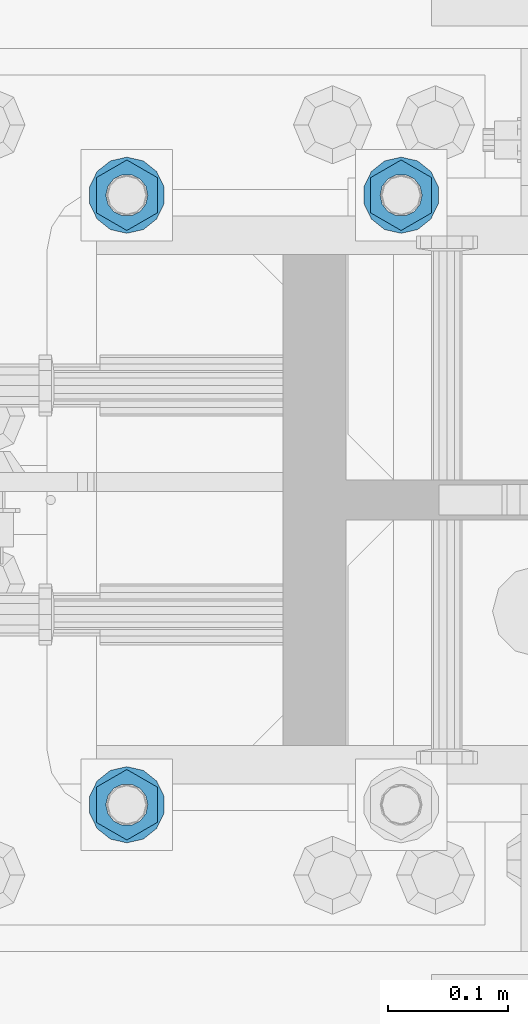
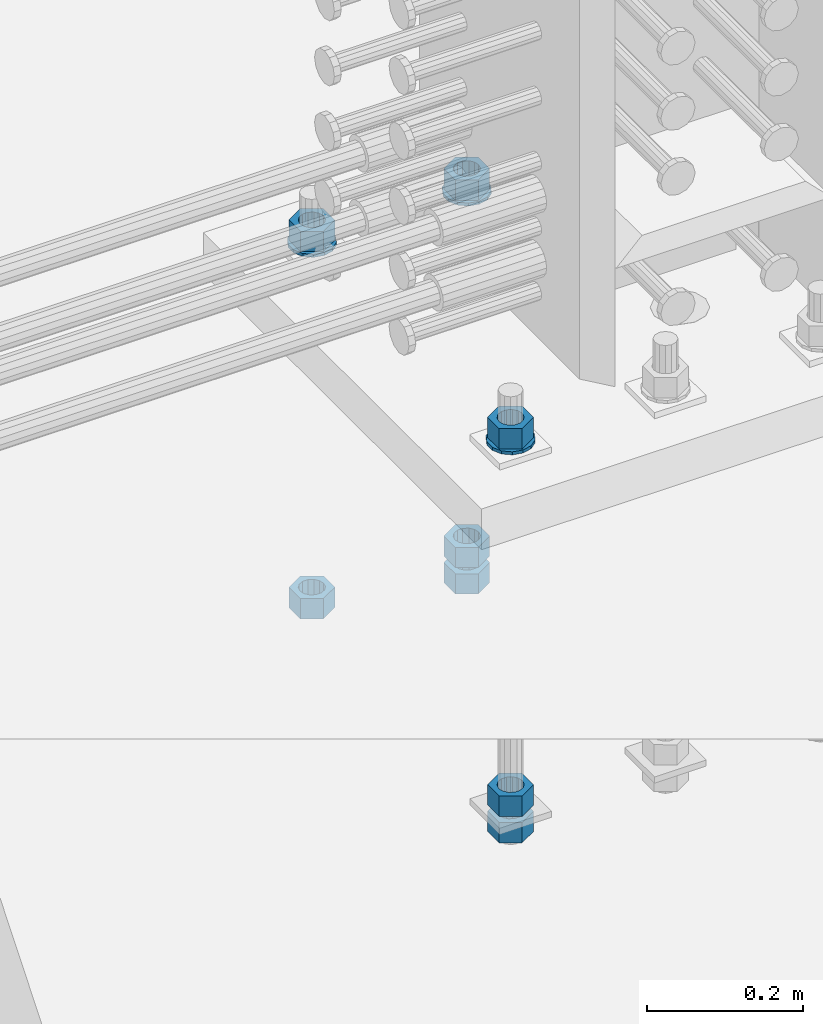
# One storey, part 1001 of 1763: 11 columns, 1 element without a shape of its own.
"""IFC2X3 building model written with IfcOpenShell, lengths in millimetres."""

from ifc_helpers import new_model, si_unit, frame, origin_with_axes, place, context, subcontext, project, spatial, faceted_brep, material, type_object, element, aggregate, save


model = new_model("IFC2X3")

# Units and contexts
model_context = context("Model", 3, precision=1e-05, world=origin_with_axes())
body_context = subcontext(model_context, "Body", "Model", "MODEL_VIEW")
ifc_project = project(units=[si_unit("LENGTHUNIT", "METRE", prefix="MILLI"), si_unit("AREAUNIT", "SQUARE_METRE"), si_unit("VOLUMEUNIT", "CUBIC_METRE"), si_unit("MASSUNIT", "GRAM", prefix="KILO"), si_unit("TIMEUNIT", "SECOND"), si_unit("PLANEANGLEUNIT", "RADIAN"), si_unit("SOLIDANGLEUNIT", "STERADIAN"), si_unit("THERMODYNAMICTEMPERATUREUNIT", "DEGREE_CELSIUS"), si_unit("LUMINOUSINTENSITYUNIT", "LUMEN")], contexts=[model_context])

# Site, building, storey
site_placement = place(None, origin_with_axes())
site = spatial("IfcSite", under=ifc_project, at=site_placement, CompositionType="ELEMENT")
building_placement = place(site_placement, origin_with_axes())
building = spatial("IfcBuilding", under=site, at=building_placement, Name="Undefined", CompositionType="ELEMENT")
storey_placement = place(building_placement, origin_with_axes())
storey = spatial("IfcBuildingStorey", under=building, at=storey_placement, Name="Undefined", CompositionType="ELEMENT", Elevation=0.0)

# Assembly, columns
assembly_placement = place(storey_placement, origin_with_axes())
assembly = element("IfcElementAssembly", 1, at=assembly_placement, inside=storey, Name="TEMPLATE", AssemblyPlace="NOTDEFINED", PredefinedType="RIGID_FRAME")
ifc_material_1 = material(Name="STEEL/A563")
column_type_1 = type_object("IfcColumnType", Name="1-1/4_HEAVY_HEX_NUT", PredefinedType="NOTDEFINED")
column_1_placement = place(assembly_placement, frame((-49516.7372736986, 711.200000000003, 3957.6375), z_axis=(-1.0, 0.0, 0.0), x_axis=(0.0, 0.0, -1.0)))
column_1 = element("IfcColumn", 2, at=column_1_placement, type_object=column_type_1, material=ifc_material_1, Name="NUT", ObjectType="1-1/4_HEAVY_HEX_NUT", context=body_context, shape_type="Brep", body=[
    faceted_brep([(0.0, -29.3700008392334, 0.0), (0.0, -14.6800003051758, -25.4300003051758), (31.75, -14.6800003051758, -25.4300003051758), (31.75, -29.3700008392334, 0.0), (0.0, 14.6800003051758, -25.4300003051758), (31.75, 14.6800003051758, -25.4300003051758), (0.0, 29.3700008392334, 0.0), (31.75, 29.3700008392334, 0.0), (0.0, 14.6800003051758, 25.4300003051758), (31.75, 14.6800003051758, 25.4300003051758), (0.0, -14.6800003051758, 25.4300003051758), (31.75, -14.6800003051758, 25.4300003051758), (0.0, 0.0, 17.4599990844727), (0.0, 7.57560968776022, 15.730915608714), (31.75, 7.57560968775942, 15.7309156087145), (31.75, 0.0, 17.4599990844727), (0.0, 13.6507769681037, 10.8861313696252), (31.75, 13.6507769681048, 10.8861313696314), (0.0, 17.0222404541215, 3.88521530314756), (31.75, 17.02224045412, 3.88521530315316), (0.0, 17.0222404541215, -3.88521530314756), (31.75, 17.02224045412, -3.88521530315332), (0.0, 13.6507769681037, -10.8861313696252), (31.75, 13.6507769681048, -10.8861313696316), (0.0, 7.57560968776022, -15.730915608714), (31.75, 7.57560968775942, -15.7309156087146), (0.0, 0.0, -17.4599990844727), (31.75, 0.0, -17.4599990844727), (0.0, -7.57560968776022, -15.730915608714), (31.75, -7.57560968775942, -15.7309156087145), (0.0, -13.6507769681037, -10.8861313696252), (31.75, -13.6507769681048, -10.8861313696314), (0.0, -17.0222404541215, -3.88521530314756), (31.75, -17.02224045412, -3.88521530315316), (0.0, -17.0222404541215, 3.88521530314756), (31.75, -17.02224045412, 3.88521530315332), (0.0, -13.6507769681037, 10.8861313696252), (31.75, -13.6507769681048, 10.8861313696316), (0.0, -7.57560968776022, 15.730915608714), (31.75, -7.57560968775942, 15.7309156087146)], [[[0, 1, 2, 3]], [[1, 4, 5, 2]], [[4, 6, 7, 5]], [[6, 8, 9, 7]], [[8, 10, 11, 9]], [[10, 0, 3, 11]], [[12, 13, 14, 15]], [[13, 16, 17, 14]], [[16, 18, 19, 17]], [[18, 20, 21, 19]], [[20, 22, 23, 21]], [[22, 24, 25, 23]], [[24, 26, 27, 25]], [[26, 28, 29, 27]], [[28, 30, 31, 29]], [[30, 32, 33, 31]], [[32, 34, 35, 33]], [[34, 36, 37, 35]], [[36, 38, 39, 37]], [[38, 12, 15, 39]], [[5, 7, 9, 11, 3, 2], [17, 19, 21, 23, 25, 27, 29, 31, 33, 35, 37, 39, 15, 14]], [[10, 8, 6, 4, 1, 0], [38, 36, 34, 32, 30, 28, 26, 24, 22, 20, 18, 16, 13, 12]]]),
])
column_2_placement = place(assembly_placement, frame((-49516.7372736986, 711.200000000003, 3384.55), z_axis=(-1.0, 0.0, 0.0), x_axis=(0.0, 0.0, -1.0)))
column_2 = element("IfcColumn", 3, at=column_2_placement, type_object=column_type_1, material=ifc_material_1, Name="NUT", ObjectType="1-1/4_HEAVY_HEX_NUT", context=body_context, shape_type="Brep", body=[
    faceted_brep([(0.0, -29.3700008392334, 0.0), (0.0, -14.6800003051758, -25.4300003051758), (31.75, -14.6800003051758, -25.4300003051758), (31.75, -29.3700008392334, 0.0), (0.0, 14.6800003051758, -25.4300003051758), (31.75, 14.6800003051758, -25.4300003051758), (0.0, 29.3700008392334, 0.0), (31.75, 29.3700008392334, 0.0), (0.0, 14.6800003051758, 25.4300003051758), (31.75, 14.6800003051758, 25.4300003051758), (0.0, -14.6800003051758, 25.4300003051758), (31.75, -14.6800003051758, 25.4300003051758), (0.0, 0.0, 17.4599990844727), (0.0, 7.57560968776022, 15.730915608714), (31.75, 7.57560968775942, 15.7309156087145), (31.75, 0.0, 17.4599990844727), (0.0, 13.6507769681037, 10.8861313696252), (31.75, 13.6507769681048, 10.8861313696314), (0.0, 17.0222404541215, 3.88521530314756), (31.75, 17.02224045412, 3.88521530315316), (0.0, 17.0222404541215, -3.88521530314756), (31.75, 17.02224045412, -3.88521530315332), (0.0, 13.6507769681037, -10.8861313696252), (31.75, 13.6507769681048, -10.8861313696316), (0.0, 7.57560968776022, -15.730915608714), (31.75, 7.57560968775942, -15.7309156087146), (0.0, 0.0, -17.4599990844727), (31.75, 0.0, -17.4599990844727), (0.0, -7.57560968776022, -15.730915608714), (31.75, -7.57560968775942, -15.7309156087145), (0.0, -13.6507769681037, -10.8861313696252), (31.75, -13.6507769681048, -10.8861313696314), (0.0, -17.0222404541215, -3.88521530314756), (31.75, -17.02224045412, -3.88521530315316), (0.0, -17.0222404541215, 3.88521530314756), (31.75, -17.02224045412, 3.88521530315332), (0.0, -13.6507769681037, 10.8861313696252), (31.75, -13.6507769681048, 10.8861313696316), (0.0, -7.57560968776022, 15.730915608714), (31.75, -7.57560968775942, 15.7309156087146)], [[[0, 1, 2, 3]], [[1, 4, 5, 2]], [[4, 6, 7, 5]], [[6, 8, 9, 7]], [[8, 10, 11, 9]], [[10, 0, 3, 11]], [[12, 13, 14, 15]], [[13, 16, 17, 14]], [[16, 18, 19, 17]], [[18, 20, 21, 19]], [[20, 22, 23, 21]], [[22, 24, 25, 23]], [[24, 26, 27, 25]], [[26, 28, 29, 27]], [[28, 30, 31, 29]], [[30, 32, 33, 31]], [[32, 34, 35, 33]], [[34, 36, 37, 35]], [[36, 38, 39, 37]], [[38, 12, 15, 39]], [[5, 7, 9, 11, 3, 2], [17, 19, 21, 23, 25, 27, 29, 31, 33, 35, 37, 39, 15, 14]], [[10, 8, 6, 4, 1, 0], [38, 36, 34, 32, 30, 28, 26, 24, 22, 20, 18, 16, 13, 12]]]),
])
column_3_placement = place(assembly_placement, frame((-49516.7372736986, 711.200000000003, 3343.275), z_axis=(-1.0, 0.0, 0.0), x_axis=(0.0, 0.0, -1.0)))
column_3 = element("IfcColumn", 4, at=column_3_placement, type_object=column_type_1, material=ifc_material_1, Name="NUT", ObjectType="1-1/4_HEAVY_HEX_NUT", context=body_context, shape_type="Brep", body=[
    faceted_brep([(0.0, -29.3700008392334, 0.0), (0.0, -14.6800003051758, -25.4300003051758), (31.75, -14.6800003051758, -25.4300003051758), (31.75, -29.3700008392334, 0.0), (0.0, 14.6800003051758, -25.4300003051758), (31.75, 14.6800003051758, -25.4300003051758), (0.0, 29.3700008392334, 0.0), (31.75, 29.3700008392334, 0.0), (0.0, 14.6800003051758, 25.4300003051758), (31.75, 14.6800003051758, 25.4300003051758), (0.0, -14.6800003051758, 25.4300003051758), (31.75, -14.6800003051758, 25.4300003051758), (0.0, 0.0, 17.4599990844727), (0.0, 7.57560968776022, 15.730915608714), (31.75, 7.57560968775942, 15.7309156087145), (31.75, 0.0, 17.4599990844727), (0.0, 13.6507769681037, 10.8861313696252), (31.75, 13.6507769681048, 10.8861313696314), (0.0, 17.0222404541215, 3.88521530314756), (31.75, 17.02224045412, 3.88521530315316), (0.0, 17.0222404541215, -3.88521530314756), (31.75, 17.02224045412, -3.88521530315332), (0.0, 13.6507769681037, -10.8861313696252), (31.75, 13.6507769681048, -10.8861313696316), (0.0, 7.57560968776022, -15.730915608714), (31.75, 7.57560968775942, -15.7309156087146), (0.0, 0.0, -17.4599990844727), (31.75, 0.0, -17.4599990844727), (0.0, -7.57560968776022, -15.730915608714), (31.75, -7.57560968775942, -15.7309156087145), (0.0, -13.6507769681037, -10.8861313696252), (31.75, -13.6507769681048, -10.8861313696314), (0.0, -17.0222404541215, -3.88521530314756), (31.75, -17.02224045412, -3.88521530315316), (0.0, -17.0222404541215, 3.88521530314756), (31.75, -17.02224045412, 3.88521530315332), (0.0, -13.6507769681037, 10.8861313696252), (31.75, -13.6507769681048, 10.8861313696316), (0.0, -7.57560968776022, 15.730915608714), (31.75, -7.57560968775942, 15.7309156087146)], [[[0, 1, 2, 3]], [[1, 4, 5, 2]], [[4, 6, 7, 5]], [[6, 8, 9, 7]], [[8, 10, 11, 9]], [[10, 0, 3, 11]], [[12, 13, 14, 15]], [[13, 16, 17, 14]], [[16, 18, 19, 17]], [[18, 20, 21, 19]], [[20, 22, 23, 21]], [[22, 24, 25, 23]], [[24, 26, 27, 25]], [[26, 28, 29, 27]], [[28, 30, 31, 29]], [[30, 32, 33, 31]], [[32, 34, 35, 33]], [[34, 36, 37, 35]], [[36, 38, 39, 37]], [[38, 12, 15, 39]], [[5, 7, 9, 11, 3, 2], [17, 19, 21, 23, 25, 27, 29, 31, 33, 35, 37, 39, 15, 14]], [[10, 8, 6, 4, 1, 0], [38, 36, 34, 32, 30, 28, 26, 24, 22, 20, 18, 16, 13, 12]]]),
])
column_4_placement = place(assembly_placement, frame((-49745.3372736986, 203.200000000003, 3957.6375), z_axis=(1.0, 0.0, 0.0), x_axis=(0.0, 0.0, -1.0)))
column_4 = element("IfcColumn", 5, at=column_4_placement, type_object=column_type_1, material=ifc_material_1, Name="NUT", ObjectType="1-1/4_HEAVY_HEX_NUT", context=body_context, shape_type="Brep", body=[
    faceted_brep([(0.0, -29.3700008392334, 0.0), (0.0, -14.6800003051758, -25.4300003051758), (31.75, -14.6800003051758, -25.4300003051758), (31.75, -29.3700008392334, 0.0), (0.0, 14.6800003051758, -25.4300003051758), (31.75, 14.6800003051758, -25.4300003051758), (0.0, 29.3700008392334, 0.0), (31.75, 29.3700008392334, 0.0), (0.0, 14.6800003051758, 25.4300003051758), (31.75, 14.6800003051758, 25.4300003051758), (0.0, -14.6800003051758, 25.4300003051758), (31.75, -14.6800003051758, 25.4300003051758), (0.0, 0.0, 17.4599990844727), (0.0, 7.57560968776022, 15.730915608714), (31.75, 7.57560968775942, 15.7309156087145), (31.75, 0.0, 17.4599990844727), (0.0, 13.6507769681037, 10.8861313696252), (31.75, 13.6507769681048, 10.8861313696314), (0.0, 17.0222404541215, 3.88521530314756), (31.75, 17.02224045412, 3.88521530315316), (0.0, 17.0222404541215, -3.88521530314756), (31.75, 17.02224045412, -3.88521530315332), (0.0, 13.6507769681037, -10.8861313696252), (31.75, 13.6507769681048, -10.8861313696316), (0.0, 7.57560968776022, -15.730915608714), (31.75, 7.57560968775942, -15.7309156087146), (0.0, 0.0, -17.4599990844727), (31.75, 0.0, -17.4599990844727), (0.0, -7.57560968776022, -15.730915608714), (31.75, -7.57560968775942, -15.7309156087145), (0.0, -13.6507769681037, -10.8861313696252), (31.75, -13.6507769681048, -10.8861313696314), (0.0, -17.0222404541215, -3.88521530314756), (31.75, -17.02224045412, -3.88521530315316), (0.0, -17.0222404541215, 3.88521530314756), (31.75, -17.02224045412, 3.88521530315332), (0.0, -13.6507769681037, 10.8861313696252), (31.75, -13.6507769681048, 10.8861313696316), (0.0, -7.57560968776022, 15.730915608714), (31.75, -7.57560968775942, 15.7309156087146)], [[[0, 1, 2, 3]], [[1, 4, 5, 2]], [[4, 6, 7, 5]], [[6, 8, 9, 7]], [[8, 10, 11, 9]], [[10, 0, 3, 11]], [[12, 13, 14, 15]], [[13, 16, 17, 14]], [[16, 18, 19, 17]], [[18, 20, 21, 19]], [[20, 22, 23, 21]], [[22, 24, 25, 23]], [[24, 26, 27, 25]], [[26, 28, 29, 27]], [[28, 30, 31, 29]], [[30, 32, 33, 31]], [[32, 34, 35, 33]], [[34, 36, 37, 35]], [[36, 38, 39, 37]], [[38, 12, 15, 39]], [[5, 7, 9, 11, 3, 2], [17, 19, 21, 23, 25, 27, 29, 31, 33, 35, 37, 39, 15, 14]], [[10, 8, 6, 4, 1, 0], [38, 36, 34, 32, 30, 28, 26, 24, 22, 20, 18, 16, 13, 12]]]),
])
column_5_placement = place(assembly_placement, frame((-49745.3372736986, 203.200000000003, 3384.55), z_axis=(1.0, 0.0, 0.0), x_axis=(0.0, 0.0, -1.0)))
column_5 = element("IfcColumn", 6, at=column_5_placement, type_object=column_type_1, material=ifc_material_1, Name="NUT", ObjectType="1-1/4_HEAVY_HEX_NUT", context=body_context, shape_type="Brep", body=[
    faceted_brep([(0.0, -29.3700008392334, 0.0), (0.0, -14.6800003051758, -25.4300003051758), (31.75, -14.6800003051758, -25.4300003051758), (31.75, -29.3700008392334, 0.0), (0.0, 14.6800003051758, -25.4300003051758), (31.75, 14.6800003051758, -25.4300003051758), (0.0, 29.3700008392334, 0.0), (31.75, 29.3700008392334, 0.0), (0.0, 14.6800003051758, 25.4300003051758), (31.75, 14.6800003051758, 25.4300003051758), (0.0, -14.6800003051758, 25.4300003051758), (31.75, -14.6800003051758, 25.4300003051758), (0.0, 0.0, 17.4599990844727), (0.0, 7.57560968776022, 15.730915608714), (31.75, 7.57560968775942, 15.7309156087145), (31.75, 0.0, 17.4599990844727), (0.0, 13.6507769681037, 10.8861313696252), (31.75, 13.6507769681048, 10.8861313696314), (0.0, 17.0222404541215, 3.88521530314756), (31.75, 17.02224045412, 3.88521530315316), (0.0, 17.0222404541215, -3.88521530314756), (31.75, 17.02224045412, -3.88521530315332), (0.0, 13.6507769681037, -10.8861313696252), (31.75, 13.6507769681048, -10.8861313696316), (0.0, 7.57560968776022, -15.730915608714), (31.75, 7.57560968775942, -15.7309156087146), (0.0, 0.0, -17.4599990844727), (31.75, 0.0, -17.4599990844727), (0.0, -7.57560968776022, -15.730915608714), (31.75, -7.57560968775942, -15.7309156087145), (0.0, -13.6507769681037, -10.8861313696252), (31.75, -13.6507769681048, -10.8861313696314), (0.0, -17.0222404541215, -3.88521530314756), (31.75, -17.02224045412, -3.88521530315316), (0.0, -17.0222404541215, 3.88521530314756), (31.75, -17.02224045412, 3.88521530315332), (0.0, -13.6507769681037, 10.8861313696252), (31.75, -13.6507769681048, 10.8861313696316), (0.0, -7.57560968776022, 15.730915608714), (31.75, -7.57560968775942, 15.7309156087146)], [[[0, 1, 2, 3]], [[1, 4, 5, 2]], [[4, 6, 7, 5]], [[6, 8, 9, 7]], [[8, 10, 11, 9]], [[10, 0, 3, 11]], [[12, 13, 14, 15]], [[13, 16, 17, 14]], [[16, 18, 19, 17]], [[18, 20, 21, 19]], [[20, 22, 23, 21]], [[22, 24, 25, 23]], [[24, 26, 27, 25]], [[26, 28, 29, 27]], [[28, 30, 31, 29]], [[30, 32, 33, 31]], [[32, 34, 35, 33]], [[34, 36, 37, 35]], [[36, 38, 39, 37]], [[38, 12, 15, 39]], [[5, 7, 9, 11, 3, 2], [17, 19, 21, 23, 25, 27, 29, 31, 33, 35, 37, 39, 15, 14]], [[10, 8, 6, 4, 1, 0], [38, 36, 34, 32, 30, 28, 26, 24, 22, 20, 18, 16, 13, 12]]]),
])
column_6_placement = place(assembly_placement, frame((-49745.3372736986, 203.200000000003, 3343.275), z_axis=(1.0, 0.0, 0.0), x_axis=(0.0, 0.0, -1.0)))
column_6 = element("IfcColumn", 7, at=column_6_placement, type_object=column_type_1, material=ifc_material_1, Name="NUT", ObjectType="1-1/4_HEAVY_HEX_NUT", context=body_context, shape_type="Brep", body=[
    faceted_brep([(0.0, -29.3700008392334, 0.0), (0.0, -14.6800003051758, -25.4300003051758), (31.75, -14.6800003051758, -25.4300003051758), (31.75, -29.3700008392334, 0.0), (0.0, 14.6800003051758, -25.4300003051758), (31.75, 14.6800003051758, -25.4300003051758), (0.0, 29.3700008392334, 0.0), (31.75, 29.3700008392334, 0.0), (0.0, 14.6800003051758, 25.4300003051758), (31.75, 14.6800003051758, 25.4300003051758), (0.0, -14.6800003051758, 25.4300003051758), (31.75, -14.6800003051758, 25.4300003051758), (0.0, 0.0, 17.4599990844727), (0.0, 7.57560968776022, 15.730915608714), (31.75, 7.57560968775942, 15.7309156087145), (31.75, 0.0, 17.4599990844727), (0.0, 13.6507769681037, 10.8861313696252), (31.75, 13.6507769681048, 10.8861313696314), (0.0, 17.0222404541215, 3.88521530314756), (31.75, 17.02224045412, 3.88521530315316), (0.0, 17.0222404541215, -3.88521530314756), (31.75, 17.02224045412, -3.88521530315332), (0.0, 13.6507769681037, -10.8861313696252), (31.75, 13.6507769681048, -10.8861313696316), (0.0, 7.57560968776022, -15.730915608714), (31.75, 7.57560968775942, -15.7309156087146), (0.0, 0.0, -17.4599990844727), (31.75, 0.0, -17.4599990844727), (0.0, -7.57560968776022, -15.730915608714), (31.75, -7.57560968775942, -15.7309156087145), (0.0, -13.6507769681037, -10.8861313696252), (31.75, -13.6507769681048, -10.8861313696314), (0.0, -17.0222404541215, -3.88521530314756), (31.75, -17.02224045412, -3.88521530315316), (0.0, -17.0222404541215, 3.88521530314756), (31.75, -17.02224045412, 3.88521530315332), (0.0, -13.6507769681037, 10.8861313696252), (31.75, -13.6507769681048, 10.8861313696316), (0.0, -7.57560968776022, 15.730915608714), (31.75, -7.57560968775942, 15.7309156087146)], [[[0, 1, 2, 3]], [[1, 4, 5, 2]], [[4, 6, 7, 5]], [[6, 8, 9, 7]], [[8, 10, 11, 9]], [[10, 0, 3, 11]], [[12, 13, 14, 15]], [[13, 16, 17, 14]], [[16, 18, 19, 17]], [[18, 20, 21, 19]], [[20, 22, 23, 21]], [[22, 24, 25, 23]], [[24, 26, 27, 25]], [[26, 28, 29, 27]], [[28, 30, 31, 29]], [[30, 32, 33, 31]], [[32, 34, 35, 33]], [[34, 36, 37, 35]], [[36, 38, 39, 37]], [[38, 12, 15, 39]], [[5, 7, 9, 11, 3, 2], [17, 19, 21, 23, 25, 27, 29, 31, 33, 35, 37, 39, 15, 14]], [[10, 8, 6, 4, 1, 0], [38, 36, 34, 32, 30, 28, 26, 24, 22, 20, 18, 16, 13, 12]]]),
])
column_7_placement = place(assembly_placement, frame((-49745.3372736986, 711.200000000003, 3957.6375), z_axis=(-1.0, 0.0, 0.0), x_axis=(0.0, 0.0, -1.0)))
column_7 = element("IfcColumn", 8, at=column_7_placement, type_object=column_type_1, material=ifc_material_1, Name="NUT", ObjectType="1-1/4_HEAVY_HEX_NUT", context=body_context, shape_type="Brep", body=[
    faceted_brep([(0.0, -29.3700008392334, 0.0), (0.0, -14.6800003051758, -25.4300003051758), (31.75, -14.6800003051758, -25.4300003051758), (31.75, -29.3700008392334, 0.0), (0.0, 14.6800003051758, -25.4300003051758), (31.75, 14.6800003051758, -25.4300003051758), (0.0, 29.3700008392334, 0.0), (31.75, 29.3700008392334, 0.0), (0.0, 14.6800003051758, 25.4300003051758), (31.75, 14.6800003051758, 25.4300003051758), (0.0, -14.6800003051758, 25.4300003051758), (31.75, -14.6800003051758, 25.4300003051758), (0.0, 0.0, 17.4599990844727), (0.0, 7.57560968776022, 15.730915608714), (31.75, 7.57560968775942, 15.7309156087145), (31.75, 0.0, 17.4599990844727), (0.0, 13.6507769681037, 10.8861313696252), (31.75, 13.6507769681048, 10.8861313696314), (0.0, 17.0222404541215, 3.88521530314756), (31.75, 17.02224045412, 3.88521530315316), (0.0, 17.0222404541215, -3.88521530314756), (31.75, 17.02224045412, -3.88521530315332), (0.0, 13.6507769681037, -10.8861313696252), (31.75, 13.6507769681048, -10.8861313696316), (0.0, 7.57560968776022, -15.730915608714), (31.75, 7.57560968775942, -15.7309156087146), (0.0, 0.0, -17.4599990844727), (31.75, 0.0, -17.4599990844727), (0.0, -7.57560968776022, -15.730915608714), (31.75, -7.57560968775942, -15.7309156087145), (0.0, -13.6507769681037, -10.8861313696252), (31.75, -13.6507769681048, -10.8861313696314), (0.0, -17.0222404541215, -3.88521530314756), (31.75, -17.02224045412, -3.88521530315316), (0.0, -17.0222404541215, 3.88521530314756), (31.75, -17.02224045412, 3.88521530315332), (0.0, -13.6507769681037, 10.8861313696252), (31.75, -13.6507769681048, 10.8861313696316), (0.0, -7.57560968776022, 15.730915608714), (31.75, -7.57560968775942, 15.7309156087146)], [[[0, 1, 2, 3]], [[1, 4, 5, 2]], [[4, 6, 7, 5]], [[6, 8, 9, 7]], [[8, 10, 11, 9]], [[10, 0, 3, 11]], [[12, 13, 14, 15]], [[13, 16, 17, 14]], [[16, 18, 19, 17]], [[18, 20, 21, 19]], [[20, 22, 23, 21]], [[22, 24, 25, 23]], [[24, 26, 27, 25]], [[26, 28, 29, 27]], [[28, 30, 31, 29]], [[30, 32, 33, 31]], [[32, 34, 35, 33]], [[34, 36, 37, 35]], [[36, 38, 39, 37]], [[38, 12, 15, 39]], [[5, 7, 9, 11, 3, 2], [17, 19, 21, 23, 25, 27, 29, 31, 33, 35, 37, 39, 15, 14]], [[10, 8, 6, 4, 1, 0], [38, 36, 34, 32, 30, 28, 26, 24, 22, 20, 18, 16, 13, 12]]]),
])
column_8_placement = place(assembly_placement, frame((-49745.3372736986, 711.200000000003, 3384.55), z_axis=(-1.0, 0.0, 0.0), x_axis=(0.0, 0.0, -1.0)))
column_8 = element("IfcColumn", 9, at=column_8_placement, type_object=column_type_1, material=ifc_material_1, Name="NUT", ObjectType="1-1/4_HEAVY_HEX_NUT", context=body_context, shape_type="Brep", body=[
    faceted_brep([(0.0, -29.3700008392334, 0.0), (0.0, -14.6800003051758, -25.4300003051758), (31.75, -14.6800003051758, -25.4300003051758), (31.75, -29.3700008392334, 0.0), (0.0, 14.6800003051758, -25.4300003051758), (31.75, 14.6800003051758, -25.4300003051758), (0.0, 29.3700008392334, 0.0), (31.75, 29.3700008392334, 0.0), (0.0, 14.6800003051758, 25.4300003051758), (31.75, 14.6800003051758, 25.4300003051758), (0.0, -14.6800003051758, 25.4300003051758), (31.75, -14.6800003051758, 25.4300003051758), (0.0, 0.0, 17.4599990844727), (0.0, 7.57560968776022, 15.730915608714), (31.75, 7.57560968775942, 15.7309156087145), (31.75, 0.0, 17.4599990844727), (0.0, 13.6507769681037, 10.8861313696252), (31.75, 13.6507769681048, 10.8861313696314), (0.0, 17.0222404541215, 3.88521530314756), (31.75, 17.02224045412, 3.88521530315316), (0.0, 17.0222404541215, -3.88521530314756), (31.75, 17.02224045412, -3.88521530315332), (0.0, 13.6507769681037, -10.8861313696252), (31.75, 13.6507769681048, -10.8861313696316), (0.0, 7.57560968776022, -15.730915608714), (31.75, 7.57560968775942, -15.7309156087146), (0.0, 0.0, -17.4599990844727), (31.75, 0.0, -17.4599990844727), (0.0, -7.57560968776022, -15.730915608714), (31.75, -7.57560968775942, -15.7309156087145), (0.0, -13.6507769681037, -10.8861313696252), (31.75, -13.6507769681048, -10.8861313696314), (0.0, -17.0222404541215, -3.88521530314756), (31.75, -17.02224045412, -3.88521530315316), (0.0, -17.0222404541215, 3.88521530314756), (31.75, -17.02224045412, 3.88521530315332), (0.0, -13.6507769681037, 10.8861313696252), (31.75, -13.6507769681048, 10.8861313696316), (0.0, -7.57560968776022, 15.730915608714), (31.75, -7.57560968775942, 15.7309156087146)], [[[0, 1, 2, 3]], [[1, 4, 5, 2]], [[4, 6, 7, 5]], [[6, 8, 9, 7]], [[8, 10, 11, 9]], [[10, 0, 3, 11]], [[12, 13, 14, 15]], [[13, 16, 17, 14]], [[16, 18, 19, 17]], [[18, 20, 21, 19]], [[20, 22, 23, 21]], [[22, 24, 25, 23]], [[24, 26, 27, 25]], [[26, 28, 29, 27]], [[28, 30, 31, 29]], [[30, 32, 33, 31]], [[32, 34, 35, 33]], [[34, 36, 37, 35]], [[36, 38, 39, 37]], [[38, 12, 15, 39]], [[5, 7, 9, 11, 3, 2], [17, 19, 21, 23, 25, 27, 29, 31, 33, 35, 37, 39, 15, 14]], [[10, 8, 6, 4, 1, 0], [38, 36, 34, 32, 30, 28, 26, 24, 22, 20, 18, 16, 13, 12]]]),
])
ifc_material_2 = material(Name="STEEL/F436")
column_type_2 = type_object("IfcColumnType", Name="1-1/4_WASHER", PredefinedType="NOTDEFINED")
column_9_placement = place(assembly_placement, frame((-49516.7372736986, 711.200000000003, 3925.8875), z_axis=(-1.0, 0.0, 0.0), x_axis=(0.0, 0.0, -1.0)))
column_9 = element("IfcColumn", 10, at=column_9_placement, type_object=column_type_2, material=ifc_material_2, Name="WASHER", ObjectType="1-1/4_WASHER", context=body_context, shape_type="Brep", body=[
    faceted_brep([(-4.54747350886464e-13, -31.7499999999964, 0.0), (0.0, -28.6057615559002, -13.7758087169827), (4.76249999999982, -28.6057615559002, -13.7758087169827), (4.76249999999982, -31.75, 0.0), (0.0, -19.795801209013, -24.8231495683602), (4.76249999999982, -19.795801209013, -24.8231495683602), (0.0, -7.06503965311276, -30.9539612117732), (4.76249999999982, -7.06503965311276, -30.9539612117732), (0.0, 7.06503965311276, -30.9539612117732), (4.76249999999982, 7.06503965311276, -30.9539612117732), (0.0, 19.7958012090166, -24.8231495683602), (4.76249999999982, 19.7958012090166, -24.8231495683602), (0.0, 28.6057615559039, -13.7758087169827), (4.76249999999982, 28.6057615559039, -13.7758087169827), (-5.91171556152403e-12, 31.7499999999891, 0.0), (4.76249999999982, 31.75, 0.0), (0.0, 28.6057615559002, 13.7758087169827), (4.76249999999982, 28.6057615559002, 13.7758087169827), (0.0, 19.795801209013, 24.8231495683602), (4.76249999999982, 19.795801209013, 24.8231495683602), (0.0, 7.06503965311276, 30.9539612117731), (4.76249999999982, 7.06503965311276, 30.9539612117731), (0.0, -7.06503965311276, 30.9539612117731), (4.76249999999982, -7.06503965311276, 30.9539612117731), (0.0, -19.7958012090166, 24.8231495683602), (4.76249999999982, -19.7958012090166, 24.8231495683602), (0.0, -28.6057615559039, 13.7758087169827), (4.76249999999982, -28.6057615559039, 13.7758087169827), (0.0, 0.0, 17.4599990844727), (0.0, 7.57560968776022, 15.730915608714), (4.76249999999982, 7.57560968775942, 15.7309156087145), (4.76249999999982, 0.0, 17.4599990844727), (0.0, 13.6507769681037, 10.8861313696252), (4.76249999999982, 13.6507769681048, 10.8861313696314), (0.0, 17.0222404541215, 3.88521530314756), (4.76249999999982, 17.02224045412, 3.88521530315316), (0.0, 17.0222404541215, -3.88521530314756), (4.76249999999982, 17.02224045412, -3.88521530315332), (0.0, 13.6507769681037, -10.8861313696252), (4.76249999999982, 13.6507769681048, -10.8861313696316), (0.0, 7.57560968776022, -15.730915608714), (4.76249999999982, 7.57560968775942, -15.7309156087146), (0.0, 0.0, -17.4599990844727), (4.76249999999982, 0.0, -17.4599990844727), (0.0, -7.57560968776022, -15.730915608714), (4.76249999999982, -7.57560968775942, -15.7309156087145), (0.0, -13.6507769681037, -10.8861313696252), (4.76249999999982, -13.6507769681048, -10.8861313696314), (0.0, -17.0222404541215, -3.88521530314756), (4.76249999999982, -17.02224045412, -3.88521530315316), (0.0, -17.0222404541215, 3.88521530314756), (4.76249999999982, -17.02224045412, 3.88521530315332), (0.0, -13.6507769681037, 10.8861313696252), (4.76249999999982, -13.6507769681048, 10.8861313696316), (0.0, -7.57560968776022, 15.730915608714), (4.76249999999982, -7.57560968775942, 15.7309156087146)], [[[0, 1, 2, 3]], [[1, 4, 5, 2]], [[4, 6, 7, 5]], [[6, 8, 9, 7]], [[8, 10, 11, 9]], [[10, 12, 13, 11]], [[12, 14, 15, 13]], [[14, 16, 17, 15]], [[16, 18, 19, 17]], [[18, 20, 21, 19]], [[20, 22, 23, 21]], [[22, 24, 25, 23]], [[24, 26, 27, 25]], [[26, 0, 3, 27]], [[28, 29, 30, 31]], [[29, 32, 33, 30]], [[32, 34, 35, 33]], [[34, 36, 37, 35]], [[36, 38, 39, 37]], [[38, 40, 41, 39]], [[40, 42, 43, 41]], [[42, 44, 45, 43]], [[44, 46, 47, 45]], [[46, 48, 49, 47]], [[48, 50, 51, 49]], [[50, 52, 53, 51]], [[52, 54, 55, 53]], [[54, 28, 31, 55]], [[5, 7, 9, 11, 13, 15, 17, 19, 21, 23, 25, 27, 3, 2], [33, 35, 37, 39, 41, 43, 45, 47, 49, 51, 53, 55, 31, 30]], [[26, 24, 22, 20, 18, 16, 14, 12, 10, 8, 6, 4, 1, 0], [54, 52, 50, 48, 46, 44, 42, 40, 38, 36, 34, 32, 29, 28]]]),
])
column_10_placement = place(assembly_placement, frame((-49745.3372736986, 203.200000000003, 3925.8875), z_axis=(1.0, 0.0, 0.0), x_axis=(0.0, 0.0, -1.0)))
column_10 = element("IfcColumn", 11, at=column_10_placement, type_object=column_type_2, material=ifc_material_2, Name="WASHER", ObjectType="1-1/4_WASHER", context=body_context, shape_type="Brep", body=[
    faceted_brep([(-4.54747350886464e-13, -31.7499999999964, 0.0), (0.0, -28.6057615559002, -13.7758087169827), (4.76249999999982, -28.6057615559002, -13.7758087169827), (4.76249999999982, -31.75, 0.0), (0.0, -19.795801209013, -24.8231495683602), (4.76249999999982, -19.795801209013, -24.8231495683602), (0.0, -7.06503965311276, -30.9539612117732), (4.76249999999982, -7.06503965311276, -30.9539612117732), (0.0, 7.06503965311276, -30.9539612117732), (4.76249999999982, 7.06503965311276, -30.9539612117732), (0.0, 19.7958012090166, -24.8231495683602), (4.76249999999982, 19.7958012090166, -24.8231495683602), (0.0, 28.6057615559039, -13.7758087169827), (4.76249999999982, 28.6057615559039, -13.7758087169827), (-5.91171556152403e-12, 31.7499999999891, 0.0), (4.76249999999982, 31.75, 0.0), (0.0, 28.6057615559002, 13.7758087169827), (4.76249999999982, 28.6057615559002, 13.7758087169827), (0.0, 19.795801209013, 24.8231495683602), (4.76249999999982, 19.795801209013, 24.8231495683602), (0.0, 7.06503965311276, 30.9539612117731), (4.76249999999982, 7.06503965311276, 30.9539612117731), (0.0, -7.06503965311276, 30.9539612117731), (4.76249999999982, -7.06503965311276, 30.9539612117731), (0.0, -19.7958012090166, 24.8231495683602), (4.76249999999982, -19.7958012090166, 24.8231495683602), (0.0, -28.6057615559039, 13.7758087169827), (4.76249999999982, -28.6057615559039, 13.7758087169827), (0.0, 0.0, 17.4599990844727), (0.0, 7.57560968776022, 15.730915608714), (4.76249999999982, 7.57560968775942, 15.7309156087145), (4.76249999999982, 0.0, 17.4599990844727), (0.0, 13.6507769681037, 10.8861313696252), (4.76249999999982, 13.6507769681048, 10.8861313696314), (0.0, 17.0222404541215, 3.88521530314756), (4.76249999999982, 17.02224045412, 3.88521530315316), (0.0, 17.0222404541215, -3.88521530314756), (4.76249999999982, 17.02224045412, -3.88521530315332), (0.0, 13.6507769681037, -10.8861313696252), (4.76249999999982, 13.6507769681048, -10.8861313696316), (0.0, 7.57560968776022, -15.730915608714), (4.76249999999982, 7.57560968775942, -15.7309156087146), (0.0, 0.0, -17.4599990844727), (4.76249999999982, 0.0, -17.4599990844727), (0.0, -7.57560968776022, -15.730915608714), (4.76249999999982, -7.57560968775942, -15.7309156087145), (0.0, -13.6507769681037, -10.8861313696252), (4.76249999999982, -13.6507769681048, -10.8861313696314), (0.0, -17.0222404541215, -3.88521530314756), (4.76249999999982, -17.02224045412, -3.88521530315316), (0.0, -17.0222404541215, 3.88521530314756), (4.76249999999982, -17.02224045412, 3.88521530315332), (0.0, -13.6507769681037, 10.8861313696252), (4.76249999999982, -13.6507769681048, 10.8861313696316), (0.0, -7.57560968776022, 15.730915608714), (4.76249999999982, -7.57560968775942, 15.7309156087146)], [[[0, 1, 2, 3]], [[1, 4, 5, 2]], [[4, 6, 7, 5]], [[6, 8, 9, 7]], [[8, 10, 11, 9]], [[10, 12, 13, 11]], [[12, 14, 15, 13]], [[14, 16, 17, 15]], [[16, 18, 19, 17]], [[18, 20, 21, 19]], [[20, 22, 23, 21]], [[22, 24, 25, 23]], [[24, 26, 27, 25]], [[26, 0, 3, 27]], [[28, 29, 30, 31]], [[29, 32, 33, 30]], [[32, 34, 35, 33]], [[34, 36, 37, 35]], [[36, 38, 39, 37]], [[38, 40, 41, 39]], [[40, 42, 43, 41]], [[42, 44, 45, 43]], [[44, 46, 47, 45]], [[46, 48, 49, 47]], [[48, 50, 51, 49]], [[50, 52, 53, 51]], [[52, 54, 55, 53]], [[54, 28, 31, 55]], [[5, 7, 9, 11, 13, 15, 17, 19, 21, 23, 25, 27, 3, 2], [33, 35, 37, 39, 41, 43, 45, 47, 49, 51, 53, 55, 31, 30]], [[26, 24, 22, 20, 18, 16, 14, 12, 10, 8, 6, 4, 1, 0], [54, 52, 50, 48, 46, 44, 42, 40, 38, 36, 34, 32, 29, 28]]]),
])
column_11_placement = place(assembly_placement, frame((-49745.3372736986, 711.200000000003, 3925.8875), z_axis=(-1.0, 0.0, 0.0), x_axis=(0.0, 0.0, -1.0)))
column_11 = element("IfcColumn", 12, at=column_11_placement, type_object=column_type_2, material=ifc_material_2, Name="WASHER", ObjectType="1-1/4_WASHER", context=body_context, shape_type="Brep", body=[
    faceted_brep([(-4.54747350886464e-13, -31.7499999999964, 0.0), (0.0, -28.6057615559002, -13.7758087169827), (4.76249999999982, -28.6057615559002, -13.7758087169827), (4.76249999999982, -31.75, 0.0), (0.0, -19.795801209013, -24.8231495683602), (4.76249999999982, -19.795801209013, -24.8231495683602), (0.0, -7.06503965311276, -30.9539612117732), (4.76249999999982, -7.06503965311276, -30.9539612117732), (0.0, 7.06503965311276, -30.9539612117732), (4.76249999999982, 7.06503965311276, -30.9539612117732), (0.0, 19.7958012090166, -24.8231495683602), (4.76249999999982, 19.7958012090166, -24.8231495683602), (0.0, 28.6057615559039, -13.7758087169827), (4.76249999999982, 28.6057615559039, -13.7758087169827), (-5.91171556152403e-12, 31.7499999999891, 0.0), (4.76249999999982, 31.75, 0.0), (0.0, 28.6057615559002, 13.7758087169827), (4.76249999999982, 28.6057615559002, 13.7758087169827), (0.0, 19.795801209013, 24.8231495683602), (4.76249999999982, 19.795801209013, 24.8231495683602), (0.0, 7.06503965311276, 30.9539612117731), (4.76249999999982, 7.06503965311276, 30.9539612117731), (0.0, -7.06503965311276, 30.9539612117731), (4.76249999999982, -7.06503965311276, 30.9539612117731), (0.0, -19.7958012090166, 24.8231495683602), (4.76249999999982, -19.7958012090166, 24.8231495683602), (0.0, -28.6057615559039, 13.7758087169827), (4.76249999999982, -28.6057615559039, 13.7758087169827), (0.0, 0.0, 17.4599990844727), (0.0, 7.57560968776022, 15.730915608714), (4.76249999999982, 7.57560968775942, 15.7309156087145), (4.76249999999982, 0.0, 17.4599990844727), (0.0, 13.6507769681037, 10.8861313696252), (4.76249999999982, 13.6507769681048, 10.8861313696314), (0.0, 17.0222404541215, 3.88521530314756), (4.76249999999982, 17.02224045412, 3.88521530315316), (0.0, 17.0222404541215, -3.88521530314756), (4.76249999999982, 17.02224045412, -3.88521530315332), (0.0, 13.6507769681037, -10.8861313696252), (4.76249999999982, 13.6507769681048, -10.8861313696316), (0.0, 7.57560968776022, -15.730915608714), (4.76249999999982, 7.57560968775942, -15.7309156087146), (0.0, 0.0, -17.4599990844727), (4.76249999999982, 0.0, -17.4599990844727), (0.0, -7.57560968776022, -15.730915608714), (4.76249999999982, -7.57560968775942, -15.7309156087145), (0.0, -13.6507769681037, -10.8861313696252), (4.76249999999982, -13.6507769681048, -10.8861313696314), (0.0, -17.0222404541215, -3.88521530314756), (4.76249999999982, -17.02224045412, -3.88521530315316), (0.0, -17.0222404541215, 3.88521530314756), (4.76249999999982, -17.02224045412, 3.88521530315332), (0.0, -13.6507769681037, 10.8861313696252), (4.76249999999982, -13.6507769681048, 10.8861313696316), (0.0, -7.57560968776022, 15.730915608714), (4.76249999999982, -7.57560968775942, 15.7309156087146)], [[[0, 1, 2, 3]], [[1, 4, 5, 2]], [[4, 6, 7, 5]], [[6, 8, 9, 7]], [[8, 10, 11, 9]], [[10, 12, 13, 11]], [[12, 14, 15, 13]], [[14, 16, 17, 15]], [[16, 18, 19, 17]], [[18, 20, 21, 19]], [[20, 22, 23, 21]], [[22, 24, 25, 23]], [[24, 26, 27, 25]], [[26, 0, 3, 27]], [[28, 29, 30, 31]], [[29, 32, 33, 30]], [[32, 34, 35, 33]], [[34, 36, 37, 35]], [[36, 38, 39, 37]], [[38, 40, 41, 39]], [[40, 42, 43, 41]], [[42, 44, 45, 43]], [[44, 46, 47, 45]], [[46, 48, 49, 47]], [[48, 50, 51, 49]], [[50, 52, 53, 51]], [[52, 54, 55, 53]], [[54, 28, 31, 55]], [[5, 7, 9, 11, 13, 15, 17, 19, 21, 23, 25, 27, 3, 2], [33, 35, 37, 39, 41, 43, 45, 47, 49, 51, 53, 55, 31, 30]], [[26, 24, 22, 20, 18, 16, 14, 12, 10, 8, 6, 4, 1, 0], [54, 52, 50, 48, 46, 44, 42, 40, 38, 36, 34, 32, 29, 28]]]),
])
aggregate(assembly, [column_1, column_9, column_2, column_3, column_4, column_10, column_5, column_6, column_7, column_11, column_8])

save(model, "model.ifc")
